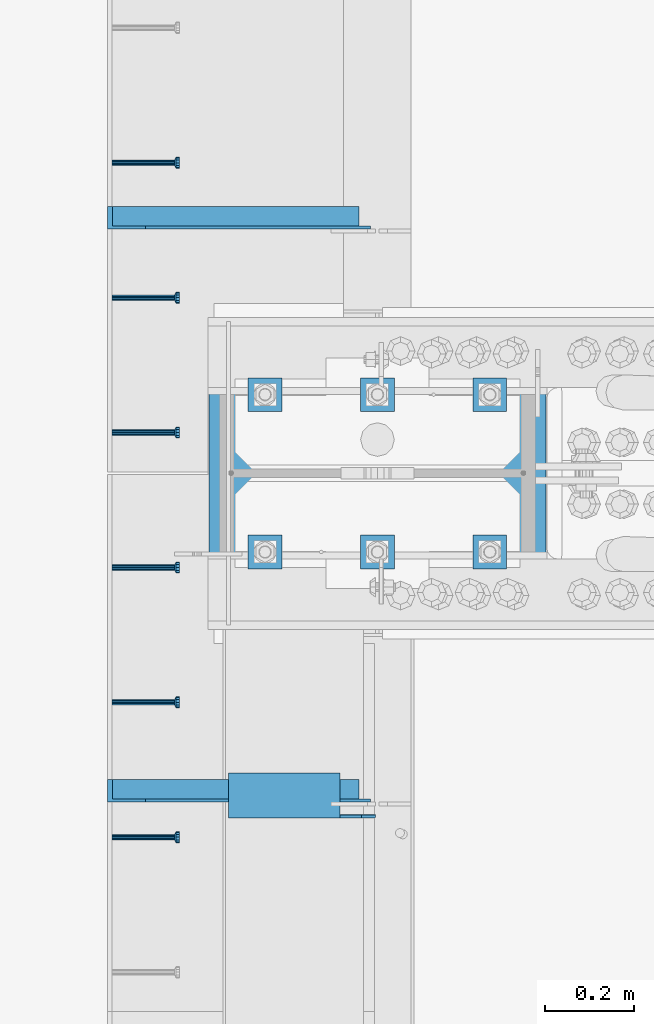
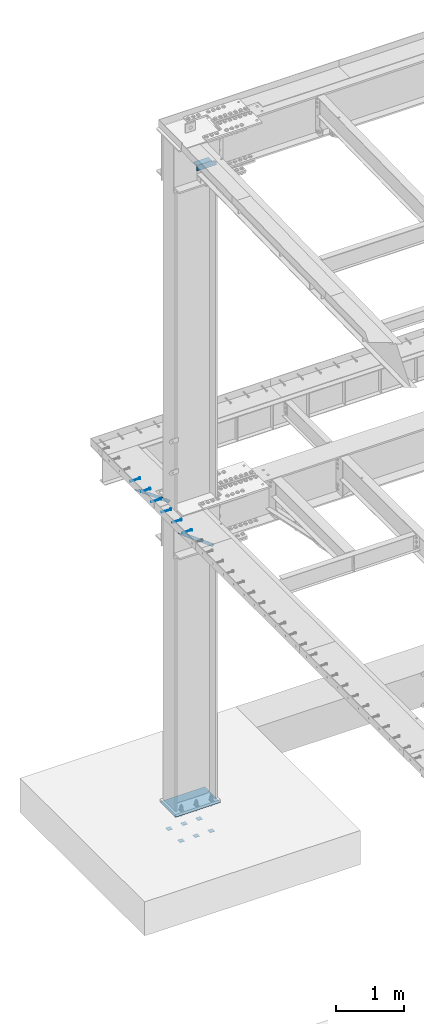
# One storey, part 1332 of 1763: 14 beams, 2 members, 10 elements without a shape of their own.
"""IFC2X3 building model written with IfcOpenShell, lengths in millimetres."""

from ifc_helpers import new_model, si_unit, frame, origin_with_axes, place, context, subcontext, project, spatial, faceted_brep, material, type_object, element, aggregate, save


model = new_model("IFC2X3")

# Units and contexts
model_context = context("Model", 3, precision=1e-05, world=origin_with_axes())
body_context = subcontext(model_context, "Body", "Model", "MODEL_VIEW")
ifc_project = project(units=[si_unit("LENGTHUNIT", "METRE", prefix="MILLI"), si_unit("AREAUNIT", "SQUARE_METRE"), si_unit("VOLUMEUNIT", "CUBIC_METRE"), si_unit("MASSUNIT", "GRAM", prefix="KILO"), si_unit("TIMEUNIT", "SECOND"), si_unit("PLANEANGLEUNIT", "RADIAN"), si_unit("SOLIDANGLEUNIT", "STERADIAN"), si_unit("THERMODYNAMICTEMPERATUREUNIT", "DEGREE_CELSIUS"), si_unit("LUMINOUSINTENSITYUNIT", "LUMEN")], contexts=[model_context])

# Site, building, storey
site_placement = place(None, origin_with_axes())
site = spatial("IfcSite", under=ifc_project, at=site_placement, CompositionType="ELEMENT")
building_placement = place(site_placement, origin_with_axes())
building = spatial("IfcBuilding", under=site, at=building_placement, Name="Undefined", CompositionType="ELEMENT")
storey_placement = place(building_placement, origin_with_axes())
storey = spatial("IfcBuildingStorey", under=building, at=storey_placement, Name="Undefined", CompositionType="ELEMENT", Elevation=0.0)

# Assembly, beam
assembly_1_placement = place(storey_placement, origin_with_axes())
assembly_1 = element("IfcElementAssembly", 1, at=assembly_1_placement, inside=storey, Name="HEADED STUD ANCHOR", AssemblyPlace="NOTDEFINED", PredefinedType="RIGID_FRAME")
ifc_material_1 = material(Name="STEEL/A108")
beam_type_1 = type_object("IfcBeamType", PredefinedType="NOTDEFINED")
beam_1_placement = place(assembly_1_placement, frame((-87975.5122736983, 51298.4750061035, 5268.91250001202), z_axis=(0.0, 0.0, -1.0), x_axis=(1.0, 0.0, 0.0)))
beam_1 = element("IfcBeam", 2, at=beam_1_placement, type_object=beam_type_1, material=ifc_material_1, Name="HEADED STUD ANCHOR", context=body_context, shape_type="Brep", body=[
    faceted_brep([(0.0, -3.1800000667572, 5.5), (0.0, -5.5, 3.1800000667572), (141.732000000002, -5.5, 3.1800000667572), (141.732000000002, -3.1800000667572, 5.5), (0.0, -6.34999999999491, 1.45519152283669e-11), (141.732000000002, -6.34999990463257, 0.0), (0.0, -5.5, -3.1800000667572), (141.732000000002, -5.5, -3.1800000667572), (0.0, -3.1800000667572, -5.5), (141.732000000002, -3.1800000667572, -5.5), (0.0, 0.0, -6.34999990463257), (141.732000000002, 0.0, -6.34999990463257), (0.0, 3.1800000667572, -5.5), (141.732000000002, 3.1800000667572, -5.5), (0.0, 5.5, -3.1800000667572), (141.732000000002, 5.5, -3.1800000667572), (0.0, 6.34999999999491, -2.91038304567337e-11), (141.732000000002, 6.34999990463257, 0.0), (0.0, 5.5, 3.1800000667572), (141.732000000002, 5.5, 3.1800000667572), (0.0, 3.1800000667572, 5.5), (141.732000000002, 3.1800000667572, 5.5), (0.0, 0.0, 6.34999990463257), (141.732000000002, 0.0, 6.34999990463257), (144.780000000001, -10.9899997711182, 6.34999990463257), (144.780000000001, -6.34000015258789, 10.9899997711182), (144.780000000001, -12.6999998092651, 0.0), (144.780000000001, -10.9899997711182, -6.34999990463257), (144.780000000001, -6.34000015258789, -10.9899997711182), (144.780000000001, 0.0, -12.6899995803833), (144.780000000001, 6.34000015258789, -10.9899997711182), (144.780000000001, 10.9899997711182, -6.34999990463257), (144.780000000001, 12.6999998092651, 0.0), (144.780000000001, 10.9899997711182, 6.34999990463257), (144.780000000001, 6.34000015258789, 10.9899997711182), (144.780000000001, 0.0, 12.6899995803833), (152.400000000001, -10.9899997711182, 6.34999990463257), (152.400000000001, -6.34000015258789, 10.9899997711182), (152.400000000001, -12.6999998092651, 0.0), (152.400000000001, -10.9899997711182, -6.34999990463257), (152.400000000001, -6.34000015258789, -10.9899997711182), (152.400000000001, 0.0, -12.6899995803833), (152.400000000001, 6.34000015258789, -10.9899997711182), (152.400000000001, 10.9899997711182, -6.34999990463257), (152.400000000001, 12.6999998092651, 0.0), (152.400000000001, 10.9899997711182, 6.34999990463257), (152.400000000001, 6.34000015258789, 10.9899997711182), (152.400000000001, 0.0, 12.6899995803833)], [[[0, 1, 2, 3]], [[1, 4, 5, 2]], [[4, 6, 7, 5]], [[6, 8, 9, 7]], [[8, 10, 11, 9]], [[10, 12, 13, 11]], [[12, 14, 15, 13]], [[14, 16, 17, 15]], [[16, 18, 19, 17]], [[18, 20, 21, 19]], [[20, 22, 23, 21]], [[22, 0, 3, 23]], [[22, 20, 18, 16, 14, 12, 10, 8, 6, 4, 1, 0]], [[3, 2, 24, 25]], [[2, 5, 26, 24]], [[5, 7, 27, 26]], [[7, 9, 28, 27]], [[9, 11, 29, 28]], [[11, 13, 30, 29]], [[13, 15, 31, 30]], [[15, 17, 32, 31]], [[17, 19, 33, 32]], [[19, 21, 34, 33]], [[21, 23, 35, 34]], [[23, 3, 25, 35]], [[25, 24, 36, 37]], [[24, 26, 38, 36]], [[26, 27, 39, 38]], [[27, 28, 40, 39]], [[28, 29, 41, 40]], [[29, 30, 42, 41]], [[30, 31, 43, 42]], [[31, 32, 44, 43]], [[32, 33, 45, 44]], [[33, 34, 46, 45]], [[34, 35, 47, 46]], [[35, 25, 37, 47]], [[38, 39, 40, 41, 42, 43, 44, 45, 46, 47, 37, 36]]]),
])
aggregate(assembly_1, [beam_1])

assembly_2_placement = place(storey_placement, origin_with_axes())
assembly_2 = element("IfcElementAssembly", 3, at=assembly_2_placement, inside=storey, Name="HEADED STUD ANCHOR", AssemblyPlace="NOTDEFINED", PredefinedType="RIGID_FRAME")
beam_2_placement = place(assembly_2_placement, frame((-87975.5122736983, 51603.2750061035, 5268.91250001202), z_axis=(0.0, 0.0, -1.0), x_axis=(1.0, 0.0, 0.0)))
beam_2 = element("IfcBeam", 4, at=beam_2_placement, type_object=beam_type_1, material=ifc_material_1, Name="HEADED STUD ANCHOR", context=body_context, shape_type="Brep", body=[
    faceted_brep([(0.0, -3.1800000667572, 5.5), (0.0, -5.5, 3.1800000667572), (141.732000000002, -5.5, 3.1800000667572), (141.732000000002, -3.1800000667572, 5.5), (0.0, -6.34999999999491, 1.45519152283669e-11), (141.732000000002, -6.34999990463257, 0.0), (0.0, -5.5, -3.1800000667572), (141.732000000002, -5.5, -3.1800000667572), (0.0, -3.1800000667572, -5.5), (141.732000000002, -3.1800000667572, -5.5), (0.0, 0.0, -6.34999990463257), (141.732000000002, 0.0, -6.34999990463257), (0.0, 3.1800000667572, -5.5), (141.732000000002, 3.1800000667572, -5.5), (0.0, 5.5, -3.1800000667572), (141.732000000002, 5.5, -3.1800000667572), (0.0, 6.34999999999491, -2.91038304567337e-11), (141.732000000002, 6.34999990463257, 0.0), (0.0, 5.5, 3.1800000667572), (141.732000000002, 5.5, 3.1800000667572), (0.0, 3.1800000667572, 5.5), (141.732000000002, 3.1800000667572, 5.5), (0.0, 0.0, 6.34999990463257), (141.732000000002, 0.0, 6.34999990463257), (144.780000000001, -10.9899997711182, 6.34999990463257), (144.780000000001, -6.34000015258789, 10.9899997711182), (144.780000000001, -12.6999998092651, 0.0), (144.780000000001, -10.9899997711182, -6.34999990463257), (144.780000000001, -6.34000015258789, -10.9899997711182), (144.780000000001, 0.0, -12.6899995803833), (144.780000000001, 6.34000015258789, -10.9899997711182), (144.780000000001, 10.9899997711182, -6.34999990463257), (144.780000000001, 12.6999998092651, 0.0), (144.780000000001, 10.9899997711182, 6.34999990463257), (144.780000000001, 6.34000015258789, 10.9899997711182), (144.780000000001, 0.0, 12.6899995803833), (152.400000000001, -10.9899997711182, 6.34999990463257), (152.400000000001, -6.34000015258789, 10.9899997711182), (152.400000000001, -12.6999998092651, 0.0), (152.400000000001, -10.9899997711182, -6.34999990463257), (152.400000000001, -6.34000015258789, -10.9899997711182), (152.400000000001, 0.0, -12.6899995803833), (152.400000000001, 6.34000015258789, -10.9899997711182), (152.400000000001, 10.9899997711182, -6.34999990463257), (152.400000000001, 12.6999998092651, 0.0), (152.400000000001, 10.9899997711182, 6.34999990463257), (152.400000000001, 6.34000015258789, 10.9899997711182), (152.400000000001, 0.0, 12.6899995803833)], [[[0, 1, 2, 3]], [[1, 4, 5, 2]], [[4, 6, 7, 5]], [[6, 8, 9, 7]], [[8, 10, 11, 9]], [[10, 12, 13, 11]], [[12, 14, 15, 13]], [[14, 16, 17, 15]], [[16, 18, 19, 17]], [[18, 20, 21, 19]], [[20, 22, 23, 21]], [[22, 0, 3, 23]], [[22, 20, 18, 16, 14, 12, 10, 8, 6, 4, 1, 0]], [[3, 2, 24, 25]], [[2, 5, 26, 24]], [[5, 7, 27, 26]], [[7, 9, 28, 27]], [[9, 11, 29, 28]], [[11, 13, 30, 29]], [[13, 15, 31, 30]], [[15, 17, 32, 31]], [[17, 19, 33, 32]], [[19, 21, 34, 33]], [[21, 23, 35, 34]], [[23, 3, 25, 35]], [[25, 24, 36, 37]], [[24, 26, 38, 36]], [[26, 27, 39, 38]], [[27, 28, 40, 39]], [[28, 29, 41, 40]], [[29, 30, 42, 41]], [[30, 31, 43, 42]], [[31, 32, 44, 43]], [[32, 33, 45, 44]], [[33, 34, 46, 45]], [[34, 35, 47, 46]], [[35, 25, 37, 47]], [[38, 39, 40, 41, 42, 43, 44, 45, 46, 47, 37, 36]]]),
])
aggregate(assembly_2, [beam_2])

assembly_3_placement = place(storey_placement, origin_with_axes())
assembly_3 = element("IfcElementAssembly", 5, at=assembly_3_placement, inside=storey, Name="HEADED STUD ANCHOR", AssemblyPlace="NOTDEFINED", PredefinedType="RIGID_FRAME")
beam_3_placement = place(assembly_3_placement, frame((-87975.5122736983, 51908.0750061035, 5268.91250001202), z_axis=(0.0, 0.0, -1.0), x_axis=(1.0, 0.0, 0.0)))
beam_3 = element("IfcBeam", 6, at=beam_3_placement, type_object=beam_type_1, material=ifc_material_1, Name="HEADED STUD ANCHOR", context=body_context, shape_type="Brep", body=[
    faceted_brep([(0.0, -3.1800000667572, 5.5), (0.0, -5.5, 3.1800000667572), (141.732000000002, -5.5, 3.1800000667572), (141.732000000002, -3.1800000667572, 5.5), (0.0, -6.34999999999491, 1.45519152283669e-11), (141.732000000002, -6.34999990463257, 0.0), (0.0, -5.5, -3.1800000667572), (141.732000000002, -5.5, -3.1800000667572), (0.0, -3.1800000667572, -5.5), (141.732000000002, -3.1800000667572, -5.5), (0.0, 0.0, -6.34999990463257), (141.732000000002, 0.0, -6.34999990463257), (0.0, 3.1800000667572, -5.5), (141.732000000002, 3.1800000667572, -5.5), (0.0, 5.5, -3.1800000667572), (141.732000000002, 5.5, -3.1800000667572), (0.0, 6.34999999999491, -2.91038304567337e-11), (141.732000000002, 6.34999990463257, 0.0), (0.0, 5.5, 3.1800000667572), (141.732000000002, 5.5, 3.1800000667572), (0.0, 3.1800000667572, 5.5), (141.732000000002, 3.1800000667572, 5.5), (0.0, 0.0, 6.34999990463257), (141.732000000002, 0.0, 6.34999990463257), (144.780000000001, -10.9899997711182, 6.34999990463257), (144.780000000001, -6.34000015258789, 10.9899997711182), (144.780000000001, -12.6999998092651, 0.0), (144.780000000001, -10.9899997711182, -6.34999990463257), (144.780000000001, -6.34000015258789, -10.9899997711182), (144.780000000001, 0.0, -12.6899995803833), (144.780000000001, 6.34000015258789, -10.9899997711182), (144.780000000001, 10.9899997711182, -6.34999990463257), (144.780000000001, 12.6999998092651, 0.0), (144.780000000001, 10.9899997711182, 6.34999990463257), (144.780000000001, 6.34000015258789, 10.9899997711182), (144.780000000001, 0.0, 12.6899995803833), (152.400000000001, -10.9899997711182, 6.34999990463257), (152.400000000001, -6.34000015258789, 10.9899997711182), (152.400000000001, -12.6999998092651, 0.0), (152.400000000001, -10.9899997711182, -6.34999990463257), (152.400000000001, -6.34000015258789, -10.9899997711182), (152.400000000001, 0.0, -12.6899995803833), (152.400000000001, 6.34000015258789, -10.9899997711182), (152.400000000001, 10.9899997711182, -6.34999990463257), (152.400000000001, 12.6999998092651, 0.0), (152.400000000001, 10.9899997711182, 6.34999990463257), (152.400000000001, 6.34000015258789, 10.9899997711182), (152.400000000001, 0.0, 12.6899995803833)], [[[0, 1, 2, 3]], [[1, 4, 5, 2]], [[4, 6, 7, 5]], [[6, 8, 9, 7]], [[8, 10, 11, 9]], [[10, 12, 13, 11]], [[12, 14, 15, 13]], [[14, 16, 17, 15]], [[16, 18, 19, 17]], [[18, 20, 21, 19]], [[20, 22, 23, 21]], [[22, 0, 3, 23]], [[22, 20, 18, 16, 14, 12, 10, 8, 6, 4, 1, 0]], [[3, 2, 24, 25]], [[2, 5, 26, 24]], [[5, 7, 27, 26]], [[7, 9, 28, 27]], [[9, 11, 29, 28]], [[11, 13, 30, 29]], [[13, 15, 31, 30]], [[15, 17, 32, 31]], [[17, 19, 33, 32]], [[19, 21, 34, 33]], [[21, 23, 35, 34]], [[23, 3, 25, 35]], [[25, 24, 36, 37]], [[24, 26, 38, 36]], [[26, 27, 39, 38]], [[27, 28, 40, 39]], [[28, 29, 41, 40]], [[29, 30, 42, 41]], [[30, 31, 43, 42]], [[31, 32, 44, 43]], [[32, 33, 45, 44]], [[33, 34, 46, 45]], [[34, 35, 47, 46]], [[35, 25, 37, 47]], [[38, 39, 40, 41, 42, 43, 44, 45, 46, 47, 37, 36]]]),
])
aggregate(assembly_3, [beam_3])

assembly_4_placement = place(storey_placement, origin_with_axes())
assembly_4 = element("IfcElementAssembly", 7, at=assembly_4_placement, inside=storey, Name="HEADED STUD ANCHOR", AssemblyPlace="NOTDEFINED", PredefinedType="RIGID_FRAME")
beam_4_placement = place(assembly_4_placement, frame((-87975.5122736983, 52212.8750061035, 5268.91250001202), z_axis=(0.0, 0.0, -1.0), x_axis=(1.0, 0.0, 0.0)))
beam_4 = element("IfcBeam", 8, at=beam_4_placement, type_object=beam_type_1, material=ifc_material_1, Name="HEADED STUD ANCHOR", context=body_context, shape_type="Brep", body=[
    faceted_brep([(0.0, -3.1800000667572, 5.5), (0.0, -5.5, 3.1800000667572), (141.732000000002, -5.5, 3.1800000667572), (141.732000000002, -3.1800000667572, 5.5), (0.0, -6.34999999999491, 1.45519152283669e-11), (141.732000000002, -6.34999990463257, 0.0), (0.0, -5.5, -3.1800000667572), (141.732000000002, -5.5, -3.1800000667572), (0.0, -3.1800000667572, -5.5), (141.732000000002, -3.1800000667572, -5.5), (0.0, 0.0, -6.34999990463257), (141.732000000002, 0.0, -6.34999990463257), (0.0, 3.1800000667572, -5.5), (141.732000000002, 3.1800000667572, -5.5), (0.0, 5.5, -3.1800000667572), (141.732000000002, 5.5, -3.1800000667572), (0.0, 6.34999999999491, -2.91038304567337e-11), (141.732000000002, 6.34999990463257, 0.0), (0.0, 5.5, 3.1800000667572), (141.732000000002, 5.5, 3.1800000667572), (0.0, 3.1800000667572, 5.5), (141.732000000002, 3.1800000667572, 5.5), (0.0, 0.0, 6.34999990463257), (141.732000000002, 0.0, 6.34999990463257), (144.780000000001, -10.9899997711182, 6.34999990463257), (144.780000000001, -6.34000015258789, 10.9899997711182), (144.780000000001, -12.6999998092651, 0.0), (144.780000000001, -10.9899997711182, -6.34999990463257), (144.780000000001, -6.34000015258789, -10.9899997711182), (144.780000000001, 0.0, -12.6899995803833), (144.780000000001, 6.34000015258789, -10.9899997711182), (144.780000000001, 10.9899997711182, -6.34999990463257), (144.780000000001, 12.6999998092651, 0.0), (144.780000000001, 10.9899997711182, 6.34999990463257), (144.780000000001, 6.34000015258789, 10.9899997711182), (144.780000000001, 0.0, 12.6899995803833), (152.400000000001, -10.9899997711182, 6.34999990463257), (152.400000000001, -6.34000015258789, 10.9899997711182), (152.400000000001, -12.6999998092651, 0.0), (152.400000000001, -10.9899997711182, -6.34999990463257), (152.400000000001, -6.34000015258789, -10.9899997711182), (152.400000000001, 0.0, -12.6899995803833), (152.400000000001, 6.34000015258789, -10.9899997711182), (152.400000000001, 10.9899997711182, -6.34999990463257), (152.400000000001, 12.6999998092651, 0.0), (152.400000000001, 10.9899997711182, 6.34999990463257), (152.400000000001, 6.34000015258789, 10.9899997711182), (152.400000000001, 0.0, 12.6899995803833)], [[[0, 1, 2, 3]], [[1, 4, 5, 2]], [[4, 6, 7, 5]], [[6, 8, 9, 7]], [[8, 10, 11, 9]], [[10, 12, 13, 11]], [[12, 14, 15, 13]], [[14, 16, 17, 15]], [[16, 18, 19, 17]], [[18, 20, 21, 19]], [[20, 22, 23, 21]], [[22, 0, 3, 23]], [[22, 20, 18, 16, 14, 12, 10, 8, 6, 4, 1, 0]], [[3, 2, 24, 25]], [[2, 5, 26, 24]], [[5, 7, 27, 26]], [[7, 9, 28, 27]], [[9, 11, 29, 28]], [[11, 13, 30, 29]], [[13, 15, 31, 30]], [[15, 17, 32, 31]], [[17, 19, 33, 32]], [[19, 21, 34, 33]], [[21, 23, 35, 34]], [[23, 3, 25, 35]], [[25, 24, 36, 37]], [[24, 26, 38, 36]], [[26, 27, 39, 38]], [[27, 28, 40, 39]], [[28, 29, 41, 40]], [[29, 30, 42, 41]], [[30, 31, 43, 42]], [[31, 32, 44, 43]], [[32, 33, 45, 44]], [[33, 34, 46, 45]], [[34, 35, 47, 46]], [[35, 25, 37, 47]], [[38, 39, 40, 41, 42, 43, 44, 45, 46, 47, 37, 36]]]),
])
aggregate(assembly_4, [beam_4])

assembly_5_placement = place(storey_placement, origin_with_axes())
assembly_5 = element("IfcElementAssembly", 9, at=assembly_5_placement, inside=storey, Name="HEADED STUD ANCHOR", AssemblyPlace="NOTDEFINED", PredefinedType="RIGID_FRAME")
beam_5_placement = place(assembly_5_placement, frame((-87975.5122736983, 52517.6750061035, 5268.91250001202), z_axis=(0.0, 0.0, -1.0), x_axis=(1.0, 0.0, 0.0)))
beam_5 = element("IfcBeam", 10, at=beam_5_placement, type_object=beam_type_1, material=ifc_material_1, Name="HEADED STUD ANCHOR", context=body_context, shape_type="Brep", body=[
    faceted_brep([(0.0, -3.1800000667572, 5.5), (0.0, -5.5, 3.1800000667572), (141.732000000002, -5.5, 3.1800000667572), (141.732000000002, -3.1800000667572, 5.5), (0.0, -6.34999999999491, 1.45519152283669e-11), (141.732000000002, -6.34999990463257, 0.0), (0.0, -5.5, -3.1800000667572), (141.732000000002, -5.5, -3.1800000667572), (0.0, -3.1800000667572, -5.5), (141.732000000002, -3.1800000667572, -5.5), (0.0, 0.0, -6.34999990463257), (141.732000000002, 0.0, -6.34999990463257), (0.0, 3.1800000667572, -5.5), (141.732000000002, 3.1800000667572, -5.5), (0.0, 5.5, -3.1800000667572), (141.732000000002, 5.5, -3.1800000667572), (0.0, 6.34999999999491, -2.91038304567337e-11), (141.732000000002, 6.34999990463257, 0.0), (0.0, 5.5, 3.1800000667572), (141.732000000002, 5.5, 3.1800000667572), (0.0, 3.1800000667572, 5.5), (141.732000000002, 3.1800000667572, 5.5), (0.0, 0.0, 6.34999990463257), (141.732000000002, 0.0, 6.34999990463257), (144.780000000001, -10.9899997711182, 6.34999990463257), (144.780000000001, -6.34000015258789, 10.9899997711182), (144.780000000001, -12.6999998092651, 0.0), (144.780000000001, -10.9899997711182, -6.34999990463257), (144.780000000001, -6.34000015258789, -10.9899997711182), (144.780000000001, 0.0, -12.6899995803833), (144.780000000001, 6.34000015258789, -10.9899997711182), (144.780000000001, 10.9899997711182, -6.34999990463257), (144.780000000001, 12.6999998092651, 0.0), (144.780000000001, 10.9899997711182, 6.34999990463257), (144.780000000001, 6.34000015258789, 10.9899997711182), (144.780000000001, 0.0, 12.6899995803833), (152.400000000001, -10.9899997711182, 6.34999990463257), (152.400000000001, -6.34000015258789, 10.9899997711182), (152.400000000001, -12.6999998092651, 0.0), (152.400000000001, -10.9899997711182, -6.34999990463257), (152.400000000001, -6.34000015258789, -10.9899997711182), (152.400000000001, 0.0, -12.6899995803833), (152.400000000001, 6.34000015258789, -10.9899997711182), (152.400000000001, 10.9899997711182, -6.34999990463257), (152.400000000001, 12.6999998092651, 0.0), (152.400000000001, 10.9899997711182, 6.34999990463257), (152.400000000001, 6.34000015258789, 10.9899997711182), (152.400000000001, 0.0, 12.6899995803833)], [[[0, 1, 2, 3]], [[1, 4, 5, 2]], [[4, 6, 7, 5]], [[6, 8, 9, 7]], [[8, 10, 11, 9]], [[10, 12, 13, 11]], [[12, 14, 15, 13]], [[14, 16, 17, 15]], [[16, 18, 19, 17]], [[18, 20, 21, 19]], [[20, 22, 23, 21]], [[22, 0, 3, 23]], [[22, 20, 18, 16, 14, 12, 10, 8, 6, 4, 1, 0]], [[3, 2, 24, 25]], [[2, 5, 26, 24]], [[5, 7, 27, 26]], [[7, 9, 28, 27]], [[9, 11, 29, 28]], [[11, 13, 30, 29]], [[13, 15, 31, 30]], [[15, 17, 32, 31]], [[17, 19, 33, 32]], [[19, 21, 34, 33]], [[21, 23, 35, 34]], [[23, 3, 25, 35]], [[25, 24, 36, 37]], [[24, 26, 38, 36]], [[26, 27, 39, 38]], [[27, 28, 40, 39]], [[28, 29, 41, 40]], [[29, 30, 42, 41]], [[30, 31, 43, 42]], [[31, 32, 44, 43]], [[32, 33, 45, 44]], [[33, 34, 46, 45]], [[34, 35, 47, 46]], [[35, 25, 37, 47]], [[38, 39, 40, 41, 42, 43, 44, 45, 46, 47, 37, 36]]]),
])
aggregate(assembly_5, [beam_5])

assembly_6_placement = place(storey_placement, origin_with_axes())
assembly_6 = element("IfcElementAssembly", 11, at=assembly_6_placement, inside=storey, Name="HEADED STUD ANCHOR", AssemblyPlace="NOTDEFINED", PredefinedType="RIGID_FRAME")
beam_6_placement = place(assembly_6_placement, frame((-87975.5122736983, 52822.4750061035, 5268.91250001202), z_axis=(0.0, 0.0, -1.0), x_axis=(1.0, 0.0, 0.0)))
beam_6 = element("IfcBeam", 12, at=beam_6_placement, type_object=beam_type_1, material=ifc_material_1, Name="HEADED STUD ANCHOR", context=body_context, shape_type="Brep", body=[
    faceted_brep([(0.0, -3.1800000667572, 5.5), (0.0, -5.5, 3.1800000667572), (141.732000000002, -5.5, 3.1800000667572), (141.732000000002, -3.1800000667572, 5.5), (0.0, -6.34999999999491, 1.45519152283669e-11), (141.732000000002, -6.34999990463257, 0.0), (0.0, -5.5, -3.1800000667572), (141.732000000002, -5.5, -3.1800000667572), (0.0, -3.1800000667572, -5.5), (141.732000000002, -3.1800000667572, -5.5), (0.0, 0.0, -6.34999990463257), (141.732000000002, 0.0, -6.34999990463257), (0.0, 3.1800000667572, -5.5), (141.732000000002, 3.1800000667572, -5.5), (0.0, 5.5, -3.1800000667572), (141.732000000002, 5.5, -3.1800000667572), (0.0, 6.34999999999491, -2.91038304567337e-11), (141.732000000002, 6.34999990463257, 0.0), (0.0, 5.5, 3.1800000667572), (141.732000000002, 5.5, 3.1800000667572), (0.0, 3.1800000667572, 5.5), (141.732000000002, 3.1800000667572, 5.5), (0.0, 0.0, 6.34999990463257), (141.732000000002, 0.0, 6.34999990463257), (144.780000000001, -10.9899997711182, 6.34999990463257), (144.780000000001, -6.34000015258789, 10.9899997711182), (144.780000000001, -12.6999998092651, 0.0), (144.780000000001, -10.9899997711182, -6.34999990463257), (144.780000000001, -6.34000015258789, -10.9899997711182), (144.780000000001, 0.0, -12.6899995803833), (144.780000000001, 6.34000015258789, -10.9899997711182), (144.780000000001, 10.9899997711182, -6.34999990463257), (144.780000000001, 12.6999998092651, 0.0), (144.780000000001, 10.9899997711182, 6.34999990463257), (144.780000000001, 6.34000015258789, 10.9899997711182), (144.780000000001, 0.0, 12.6899995803833), (152.400000000001, -10.9899997711182, 6.34999990463257), (152.400000000001, -6.34000015258789, 10.9899997711182), (152.400000000001, -12.6999998092651, 0.0), (152.400000000001, -10.9899997711182, -6.34999990463257), (152.400000000001, -6.34000015258789, -10.9899997711182), (152.400000000001, 0.0, -12.6899995803833), (152.400000000001, 6.34000015258789, -10.9899997711182), (152.400000000001, 10.9899997711182, -6.34999990463257), (152.400000000001, 12.6999998092651, 0.0), (152.400000000001, 10.9899997711182, 6.34999990463257), (152.400000000001, 6.34000015258789, 10.9899997711182), (152.400000000001, 0.0, 12.6899995803833)], [[[0, 1, 2, 3]], [[1, 4, 5, 2]], [[4, 6, 7, 5]], [[6, 8, 9, 7]], [[8, 10, 11, 9]], [[10, 12, 13, 11]], [[12, 14, 15, 13]], [[14, 16, 17, 15]], [[16, 18, 19, 17]], [[18, 20, 21, 19]], [[20, 22, 23, 21]], [[22, 0, 3, 23]], [[22, 20, 18, 16, 14, 12, 10, 8, 6, 4, 1, 0]], [[3, 2, 24, 25]], [[2, 5, 26, 24]], [[5, 7, 27, 26]], [[7, 9, 28, 27]], [[9, 11, 29, 28]], [[11, 13, 30, 29]], [[13, 15, 31, 30]], [[15, 17, 32, 31]], [[17, 19, 33, 32]], [[19, 21, 34, 33]], [[21, 23, 35, 34]], [[23, 3, 25, 35]], [[25, 24, 36, 37]], [[24, 26, 38, 36]], [[26, 27, 39, 38]], [[27, 28, 40, 39]], [[28, 29, 41, 40]], [[29, 30, 42, 41]], [[30, 31, 43, 42]], [[31, 32, 44, 43]], [[32, 33, 45, 44]], [[33, 34, 46, 45]], [[34, 35, 47, 46]], [[35, 25, 37, 47]], [[38, 39, 40, 41, 42, 43, 44, 45, 46, 47, 37, 36]]]),
])
aggregate(assembly_6, [beam_6])

# Assembly, member
assembly_7_placement = place(storey_placement, origin_with_axes())
assembly_7 = element("IfcElementAssembly", 13, at=assembly_7_placement, inside=storey, Name="BEAM", AssemblyPlace="NOTDEFINED", PredefinedType="RIGID_FRAME")
ifc_material_2 = material(Name="STEEL/A36")
member_type = type_object("IfcMemberType", Name="L2X2X1/4", PredefinedType="NOTDEFINED")
member_1_placement = place(assembly_7_placement, frame((-87406.0995933455, 51404.04375, 4794.78284113776), z_axis=(0.597323303215295, 0.0, 0.802000543289074), x_axis=(-0.802000543289071, 0.0, 0.597323303215297)))
member_1 = element("IfcMember", 14, at=member_1_placement, type_object=member_type, material=ifc_material_2, Name="ANGLE", ObjectType="L2X2X1/4", context=body_context, shape_type="Brep", body=[
    faceted_brep([(-1.45519152283669e-11, 25.4000000000015, -25.3999999999869), (1.45519152283669e-11, 25.4000000000015, 25.3999999999796), (634.74226311341, 25.4000000000015, 25.3999999990119), (702.949257616929, 25.4000000000015, -25.4000000010055), (1.45519152283669e-11, 19.0499999999993, 25.3999999999796), (634.74226311341, 19.0500000000029, 25.3999999990119), (-7.27595761418343e-12, 19.0499999999993, -19.0499999999956), (694.423383303991, 19.0500000000029, -19.050000001007), (-7.27595761418343e-12, -25.4000000000015, -19.0499999999956), (694.423383303991, -25.4000000000015, -19.050000001007), (-1.45519152283669e-11, -25.4000000000015, -25.3999999999869), (702.949257616929, -25.4000000000015, -25.4000000010055)], [[[0, 1, 2, 3]], [[1, 4, 5, 2]], [[4, 6, 7, 5]], [[6, 8, 9, 7]], [[8, 10, 11, 9]], [[10, 0, 3, 11]], [[5, 7, 9, 11, 3, 2]], [[10, 8, 6, 4, 1, 0]]]),
])
aggregate(assembly_7, [member_1])

assembly_8_placement = place(storey_placement, origin_with_axes())
assembly_8 = element("IfcElementAssembly", 15, at=assembly_8_placement, inside=storey, Name="BEAM", AssemblyPlace="NOTDEFINED", PredefinedType="RIGID_FRAME")
member_2_placement = place(assembly_8_placement, frame((-87406.0995928357, 52698.253125, 4794.78284056438), z_axis=(0.597323303215295, 0.0, 0.802000543289074), x_axis=(-0.802000543289071, 0.0, 0.597323303215297)))
member_2 = element("IfcMember", 16, at=member_2_placement, type_object=member_type, material=ifc_material_2, Name="ANGLE", ObjectType="L2X2X1/4", context=body_context, shape_type="Brep", body=[
    faceted_brep([(-1.45519152283669e-11, 25.4000000000015, -25.3999999999869), (1.45519152283669e-11, 25.4000000000015, 25.3999999999796), (634.74226311341, 25.4000000000015, 25.3999999990119), (702.949257616929, 25.4000000000015, -25.4000000010055), (1.45519152283669e-11, 19.0499999999993, 25.3999999999796), (634.74226311341, 19.0500000000029, 25.3999999990119), (-7.27595761418343e-12, 19.0499999999993, -19.0499999999956), (694.423383303991, 19.0500000000029, -19.050000001007), (-7.27595761418343e-12, -25.4000000000015, -19.0499999999956), (694.423383303991, -25.4000000000015, -19.050000001007), (-1.45519152283669e-11, -25.4000000000015, -25.3999999999869), (702.949257616929, -25.4000000000015, -25.4000000010055)], [[[0, 1, 2, 3]], [[1, 4, 5, 2]], [[4, 6, 7, 5]], [[6, 8, 9, 7]], [[8, 10, 11, 9]], [[10, 0, 3, 11]], [[5, 7, 9, 11, 3, 2]], [[10, 8, 6, 4, 1, 0]]]),
])
aggregate(assembly_8, [member_2])

# Assembly, beam
assembly_9_placement = place(storey_placement, origin_with_axes())
assembly_9 = element("IfcElementAssembly", 17, at=assembly_9_placement, inside=storey, Name="BEAM", AssemblyPlace="NOTDEFINED", PredefinedType="RIGID_FRAME")
beam_type_2 = type_object("IfcBeamType", Name="L4X4X1/4", PredefinedType="NOTDEFINED")
beam_7_placement = place(assembly_9_placement, frame((-87711.987270646, 51393.4025030876, 11681.6395170387), z_axis=(0.0, 0.0206852279954837, -0.999786037781472), x_axis=(1.0, 0.0, 0.0)))
beam_7 = element("IfcBeam", 18, at=beam_7_placement, type_object=beam_type_2, material=ifc_material_2, Name="BRACE", ObjectType="L4X4X1/4", context=body_context, shape_type="Brep", body=[
    faceted_brep([(331.787533980634, 44.4500000001281, -4.76249998546336), (300.037521174891, 44.4500000001135, -36.4878036928512), (300.037521174891, 50.8000000001412, -36.4878037045546), (331.787546948486, 50.8000000001412, -4.76249998546518), (1.96450855582952e-10, -50.8000000000338, -44.4499999999534), (2.11002770811319e-10, -50.8000000000357, -50.799999999952), (252.412497029261, -50.800000000163, -50.7999999999502), (252.412491263516, -50.800000000163, -44.4499999999534), (-3.63797880709171e-11, 50.8000000000011, -50.8000000000538), (252.41249694943, 50.8000000001412, -50.7999999999756), (252.412491188385, 44.4500000001135, -44.4499999999807), (252.41248397647, 50.8000000001339, -36.5124986658775), (252.412483981447, 44.4500000001135, -36.5124986595329), (-2.18278728425503e-11, 44.4500000000007, -44.450000000048), (-1.81898940354586e-10, 44.4500000000371, 50.7999999999374), (-1.96450855582952e-10, 50.8000000000393, 50.7999999999374), (331.787546948486, 44.4500000001353, 50.7999999999502), (331.787546948486, 50.8000000001557, 50.7999999999465)], [[[0, 1, 2, 3]], [[4, 5, 6, 7]], [[5, 8, 9, 6]], [[10, 7, 6, 9, 11, 12]], [[13, 4, 7, 10]], [[5, 4, 13, 14, 15, 8]], [[15, 14, 16, 17]], [[17, 16, 0, 3]], [[11, 9, 8, 15, 17, 3, 2]], [[12, 11, 2, 1]], [[16, 14, 13, 10, 12, 1, 0]]]),
])
aggregate(assembly_9, [beam_7])

# Assembly, beams
assembly_10_placement = place(storey_placement, origin_with_axes())
assembly_10 = element("IfcElementAssembly", 19, at=assembly_10_placement, inside=storey, Name="TEMPLATE", AssemblyPlace="NOTDEFINED", PredefinedType="RIGID_FRAME")
beam_type_3 = type_object("IfcBeamType", PredefinedType="NOTDEFINED")
beam_8_placement = place(assembly_10_placement, frame((-87083.3372736983, 51943.0, -758.825000000016), z_axis=(0.0, 1.0, 0.0), x_axis=(-1.0, 0.0, 0.0)))
beam_8 = element("IfcBeam", 20, at=beam_8_placement, type_object=beam_type_3, material=ifc_material_2, Name="WASHER PLATE", context=body_context, shape_type="Brep", body=[
    faceted_brep([(0.0, 3.17500000000018, -38.0999999999985), (0.0, 3.17500000000018, 38.0999999999985), (76.1999999999971, 3.17499999999995, 38.0999999999985), (76.1999999999971, 3.17499999999995, -38.0999999999985), (0.0, -3.17500000000018, 38.0999999999985), (76.1999999999971, -3.17499999999995, 38.0999999999985), (0.0, -3.17500000000018, -38.0999999999985), (76.1999999999971, -3.17499999999995, -38.0999999999985)], [[[0, 1, 2, 3]], [[1, 4, 5, 2]], [[4, 6, 7, 5]], [[6, 0, 3, 7]], [[5, 7, 3, 2]], [[6, 4, 1, 0]]]),
])
beam_9_placement = place(assembly_10_placement, frame((-87083.3372736983, 52298.6, -758.825000000016), z_axis=(0.0, 1.0, 0.0), x_axis=(-1.0, 0.0, 0.0)))
beam_9 = element("IfcBeam", 21, at=beam_9_placement, type_object=beam_type_3, material=ifc_material_2, Name="WASHER PLATE", context=body_context, shape_type="Brep", body=[
    faceted_brep([(0.0, 3.17500000000018, -38.0999999999985), (0.0, 3.17500000000018, 38.0999999999985), (76.1999999999971, 3.17499999999995, 38.0999999999985), (76.1999999999971, 3.17499999999995, -38.0999999999985), (0.0, -3.17500000000018, 38.0999999999985), (76.1999999999971, -3.17499999999995, 38.0999999999985), (0.0, -3.17500000000018, -38.0999999999985), (76.1999999999971, -3.17499999999995, -38.0999999999985)], [[[0, 1, 2, 3]], [[1, 4, 5, 2]], [[4, 6, 7, 5]], [[6, 0, 3, 7]], [[5, 7, 3, 2]], [[6, 4, 1, 0]]]),
])
beam_10_placement = place(assembly_10_placement, frame((-87337.3372736983, 51943.0, -758.825000000016), z_axis=(0.0, 1.0, 0.0), x_axis=(-1.0, 0.0, 0.0)))
beam_10 = element("IfcBeam", 22, at=beam_10_placement, type_object=beam_type_3, material=ifc_material_2, Name="WASHER PLATE", context=body_context, shape_type="Brep", body=[
    faceted_brep([(0.0, 3.17500000000018, -38.0999999999985), (0.0, 3.17500000000018, 38.0999999999985), (76.1999999999971, 3.17499999999995, 38.0999999999985), (76.1999999999971, 3.17499999999995, -38.0999999999985), (0.0, -3.17500000000018, 38.0999999999985), (76.1999999999971, -3.17499999999995, 38.0999999999985), (0.0, -3.17500000000018, -38.0999999999985), (76.1999999999971, -3.17499999999995, -38.0999999999985)], [[[0, 1, 2, 3]], [[1, 4, 5, 2]], [[4, 6, 7, 5]], [[6, 0, 3, 7]], [[5, 7, 3, 2]], [[6, 4, 1, 0]]]),
])
beam_11_placement = place(assembly_10_placement, frame((-87337.3372736983, 52298.6, -758.825000000016), z_axis=(0.0, 1.0, 0.0), x_axis=(-1.0, 0.0, 0.0)))
beam_11 = element("IfcBeam", 23, at=beam_11_placement, type_object=beam_type_3, material=ifc_material_2, Name="WASHER PLATE", context=body_context, shape_type="Brep", body=[
    faceted_brep([(0.0, 3.17500000000018, -38.0999999999985), (0.0, 3.17500000000018, 38.0999999999985), (76.1999999999971, 3.17499999999995, 38.0999999999985), (76.1999999999971, 3.17499999999995, -38.0999999999985), (0.0, -3.17500000000018, 38.0999999999985), (76.1999999999971, -3.17499999999995, 38.0999999999985), (0.0, -3.17500000000018, -38.0999999999985), (76.1999999999971, -3.17499999999995, -38.0999999999985)], [[[0, 1, 2, 3]], [[1, 4, 5, 2]], [[4, 6, 7, 5]], [[6, 0, 3, 7]], [[5, 7, 3, 2]], [[6, 4, 1, 0]]]),
])
beam_12_placement = place(assembly_10_placement, frame((-87591.3372736983, 51943.0, -758.825000000016), z_axis=(0.0, 1.0, 0.0), x_axis=(-1.0, 0.0, 0.0)))
beam_12 = element("IfcBeam", 24, at=beam_12_placement, type_object=beam_type_3, material=ifc_material_2, Name="WASHER PLATE", context=body_context, shape_type="Brep", body=[
    faceted_brep([(0.0, 3.17500000000018, -38.0999999999985), (0.0, 3.17500000000018, 38.0999999999985), (76.1999999999971, 3.17499999999995, 38.0999999999985), (76.1999999999971, 3.17499999999995, -38.0999999999985), (0.0, -3.17500000000018, 38.0999999999985), (76.1999999999971, -3.17499999999995, 38.0999999999985), (0.0, -3.17500000000018, -38.0999999999985), (76.1999999999971, -3.17499999999995, -38.0999999999985)], [[[0, 1, 2, 3]], [[1, 4, 5, 2]], [[4, 6, 7, 5]], [[6, 0, 3, 7]], [[5, 7, 3, 2]], [[6, 4, 1, 0]]]),
])
beam_13_placement = place(assembly_10_placement, frame((-87591.3372736983, 52298.6, -758.825000000016), z_axis=(0.0, 1.0, 0.0), x_axis=(-1.0, 0.0, 0.0)))
beam_13 = element("IfcBeam", 25, at=beam_13_placement, type_object=beam_type_3, material=ifc_material_2, Name="WASHER PLATE", context=body_context, shape_type="Brep", body=[
    faceted_brep([(0.0, 3.17500000000018, -38.0999999999985), (0.0, 3.17500000000018, 38.0999999999985), (76.1999999999971, 3.17499999999995, 38.0999999999985), (76.1999999999971, 3.17499999999995, -38.0999999999985), (0.0, -3.17500000000018, 38.0999999999985), (76.1999999999971, -3.17499999999995, 38.0999999999985), (0.0, -3.17500000000018, -38.0999999999985), (76.1999999999971, -3.17499999999995, -38.0999999999985)], [[[0, 1, 2, 3]], [[1, 4, 5, 2]], [[4, 6, 7, 5]], [[6, 0, 3, 7]], [[5, 7, 3, 2]], [[6, 4, 1, 0]]]),
])
beam_type_4 = type_object("IfcBeamType", PredefinedType="NOTDEFINED")
beam_14_placement = place(assembly_10_placement, frame((-86994.4372736983, 52120.8, -263.525000000016), z_axis=(0.0, -1.0, 0.0), x_axis=(-1.0, 0.0, 0.0)))
beam_14 = element("IfcBeam", 26, at=beam_14_placement, type_object=beam_type_4, material=ifc_material_2, Name="TEMPLATE", context=body_context, shape_type="Brep", body=[
    faceted_brep([(0.0, 3.17500000000001, -228.599999999999), (0.0, 3.17500000000001, 228.599999999999), (762.0, 3.17500000000001, 228.599999999999), (762.0, 3.17500000000001, -228.599999999999), (0.0, -3.17500000000001, 228.599999999999), (762.0, -3.17500000000001, 228.599999999999), (0.0, -3.17500000000001, -228.599999999999), (762.0, -3.17500000000001, -228.599999999999)], [[[0, 1, 2, 3]], [[1, 4, 5, 2]], [[4, 6, 7, 5]], [[6, 0, 3, 7]], [[5, 7, 3, 2]], [[6, 4, 1, 0]]]),
])
aggregate(assembly_10, [beam_8, beam_9, beam_10, beam_11, beam_12, beam_13, beam_14])

save(model, "model.ifc")
